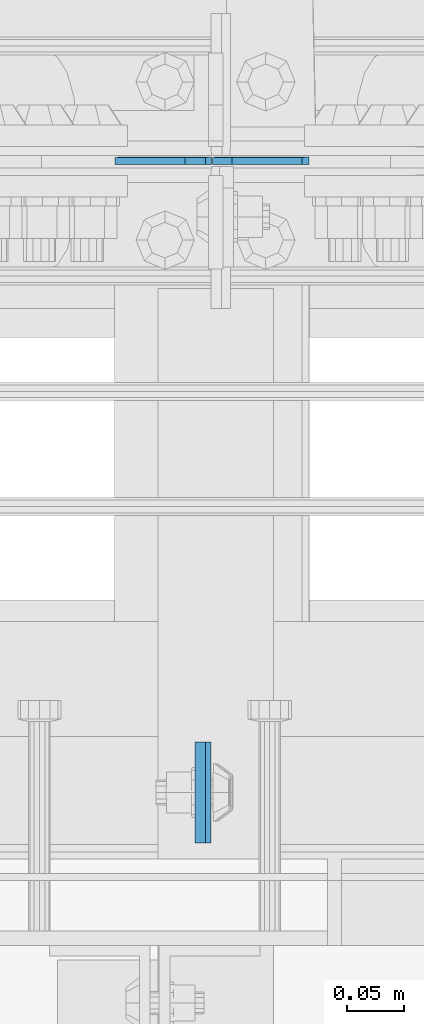
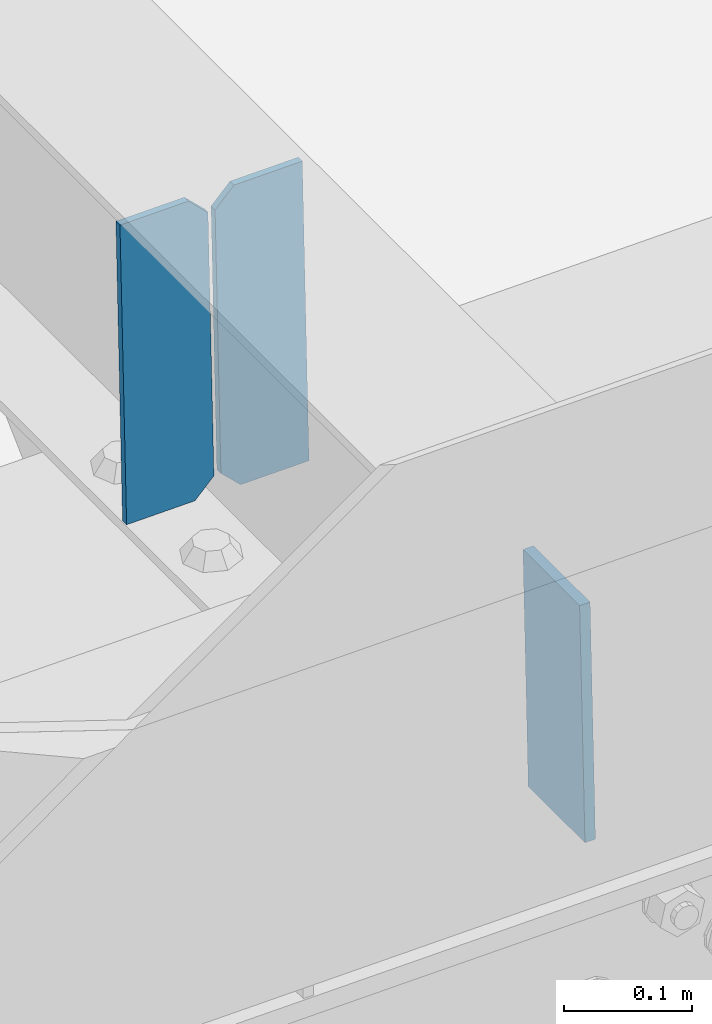
# One storey, part 3128 of 3843: 3 plates, 2 elements without a shape of their own.
"""IFC2X3 building model written with IfcOpenShell, lengths in millimetres."""

from ifc_helpers import new_model, si_unit, frame, origin_with_axes, place, context, subcontext, project, spatial, faceted_brep, material, type_object, element, aggregate, save


model = new_model("IFC2X3")

# Units and contexts
model_context = context("Model", 3, precision=1e-05, world=origin_with_axes())
body_context = subcontext(model_context, "Body", "Model", "MODEL_VIEW")
ifc_project = project(units=[si_unit("LENGTHUNIT", "METRE", prefix="MILLI"), si_unit("AREAUNIT", "SQUARE_METRE"), si_unit("VOLUMEUNIT", "CUBIC_METRE"), si_unit("MASSUNIT", "GRAM", prefix="KILO"), si_unit("TIMEUNIT", "SECOND"), si_unit("PLANEANGLEUNIT", "RADIAN"), si_unit("SOLIDANGLEUNIT", "STERADIAN"), si_unit("THERMODYNAMICTEMPERATUREUNIT", "DEGREE_CELSIUS"), si_unit("LUMINOUSINTENSITYUNIT", "LUMEN")], contexts=[model_context])

# Site, building, storey
site_placement = place(None, origin_with_axes())
site = spatial("IfcSite", under=ifc_project, at=site_placement, CompositionType="ELEMENT")
building_placement = place(site_placement, origin_with_axes())
building = spatial("IfcBuilding", under=site, at=building_placement, Name="Undefined", CompositionType="ELEMENT")
storey_placement = place(building_placement, origin_with_axes())
storey = spatial("IfcBuildingStorey", under=building, at=storey_placement, Name="Undefined", CompositionType="ELEMENT", Elevation=0.0)

# Assembly, plate
assembly_1_placement = place(storey_placement, origin_with_axes())
assembly_1 = element("IfcElementAssembly", 1, at=assembly_1_placement, inside=storey, Name="BEAM", AssemblyPlace="NOTDEFINED", PredefinedType="RIGID_FRAME")
ifc_material = material(Name="STEEL/A572-50")
plate_type_1 = type_object("IfcPlateType", PredefinedType="NOTDEFINED")
plate_1_placement = place(assembly_1_placement, frame((45515.7882361087, 25014.2375493127, 45880.6493295809), z_axis=(1.0335007274989e-05, 0.99999999994657, 2.18655972275883e-07), x_axis=(0.0211520550054438, 0.0, -0.999776270257025)))
plate_1 = element("IfcPlate", 2, at=plate_1_placement, type_object=plate_type_1, material=ifc_material, Name="PLATE", context=body_context, shape_type="Brep", body=[
    faceted_brep([(0.0, -4.76249999999709, 0.0), (0.0, -4.76249999999709, 88.9000015258789), (0.0, 4.76249999999709, 88.9000015258789), (0.0, 4.76249999999709, 0.0), (228.600006102781, -4.7625000004191, 88.9000015257589), (228.600006102781, 4.76249999954598, 88.9000015257443), (228.600006103079, -4.7625000004482, 7.27595761418343e-12), (228.600006103079, 4.76249999954598, -7.27595761418343e-12)], [[[0, 1, 2, 3]], [[1, 4, 5, 2]], [[4, 6, 7, 5]], [[6, 0, 3, 7]], [[5, 7, 3, 2]], [[6, 4, 1, 0]]]),
])
aggregate(assembly_1, [plate_1])

# Assembly, plates
assembly_2_placement = place(storey_placement, origin_with_axes())
assembly_2 = element("IfcElementAssembly", 3, at=assembly_2_placement, inside=storey, Name="BEAM", AssemblyPlace="NOTDEFINED", PredefinedType="RIGID_FRAME")
plate_type_2 = type_object("IfcPlateType", PredefinedType="NOTDEFINED")
plate_2_placement = place(assembly_2_placement, frame((45611.796478265, 25616.1160847343, 45620.9568443236), z_axis=(-0.0211520975334279, -0.000488612999983161, 0.999776149959216), x_axis=(-0.999776269357268, 1.0337000006824e-05, -0.0211520950075907)))
plate_2 = element("IfcPlate", 4, at=plate_2_placement, type_object=plate_type_2, material=ifc_material, Name="STIFFENER", context=body_context, shape_type="Brep", body=[
    faceted_brep([(0.0, -3.17499999999927, 0.0), (6.83940015733242e-10, -3.17499999996653, 288.924999998613), (6.54836185276508e-10, 3.17500000001746, 288.924999998591), (0.0, 3.17499999999927, 0.0), (61.9125003828667, -3.17499999997744, 288.924999998599), (61.9125003828522, 3.17500000002838, 288.924999998584), (79.3750000013097, -3.17499999997744, 271.462500380039), (79.375000001266, 3.17500000002838, 271.462500380017), (79.375000000713, -3.17499999999927, 17.4624996185448), (79.3750000006694, 3.17500000000291, 17.462499618523), (61.9125003821828, -3.17499999999563, -1.45519152283669e-11), (61.9125003821682, 3.17500000000655, -2.91038304567337e-11)], [[[0, 1, 2, 3]], [[1, 4, 5, 2]], [[4, 6, 7, 5]], [[6, 8, 9, 7]], [[8, 10, 11, 9]], [[10, 0, 3, 11]], [[5, 7, 9, 11, 3, 2]], [[10, 8, 6, 4, 1, 0]]]),
])
plate_3_placement = place(assembly_2_placement, frame((45526.0906575754, 25616.1169709161, 45619.1435809388), z_axis=(-0.0211520975334279, -0.000488612999983161, 0.999776149959216), x_axis=(-0.999776269357268, 1.0337000006824e-05, -0.0211520950075907)))
plate_3 = element("IfcPlate", 5, at=plate_3_placement, type_object=plate_type_2, material=ifc_material, Name="STIFFENER", context=body_context, shape_type="Brep", body=[
    faceted_brep([(5.82076609134674e-11, -3.17499999999927, 17.4624996185667), (6.25732354819775e-10, -3.17499999997744, 271.462500380054), (5.82076609134674e-10, 3.17500000002474, 271.462500380039), (0.0, 3.17500000000655, 17.4624996185521), (17.462499619156, -3.17499999997744, 288.924999998606), (17.4624996191269, 3.17500000002474, 288.924999998591), (79.3750000013242, -3.17500000025029, 288.924999998591), (79.3750000013097, 3.1749999997337, 288.92499999857), (79.3750000006548, -3.17500000026484, -2.18278728425503e-11), (79.3750000006403, 3.17499999969732, -2.91038304567337e-11), (17.4624996184866, -3.17500000000291, 7.27595761418343e-12), (17.462499618443, 3.17500000000291, -7.27595761418343e-12)], [[[0, 1, 2, 3]], [[1, 4, 5, 2]], [[4, 6, 7, 5]], [[6, 8, 9, 7]], [[8, 10, 11, 9]], [[10, 0, 3, 11]], [[5, 7, 9, 11, 3, 2]], [[10, 8, 6, 4, 1, 0]]]),
])
aggregate(assembly_2, [plate_2, plate_3])

save(model, "model.ifc")
